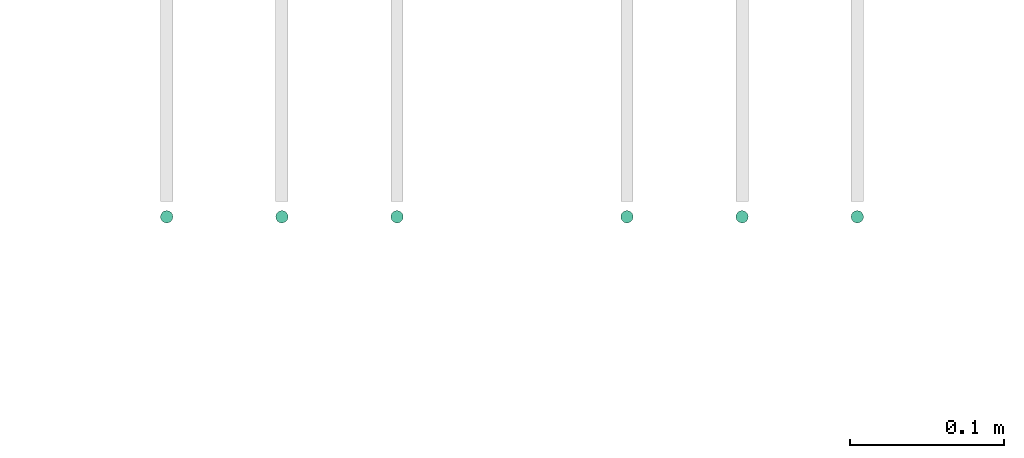
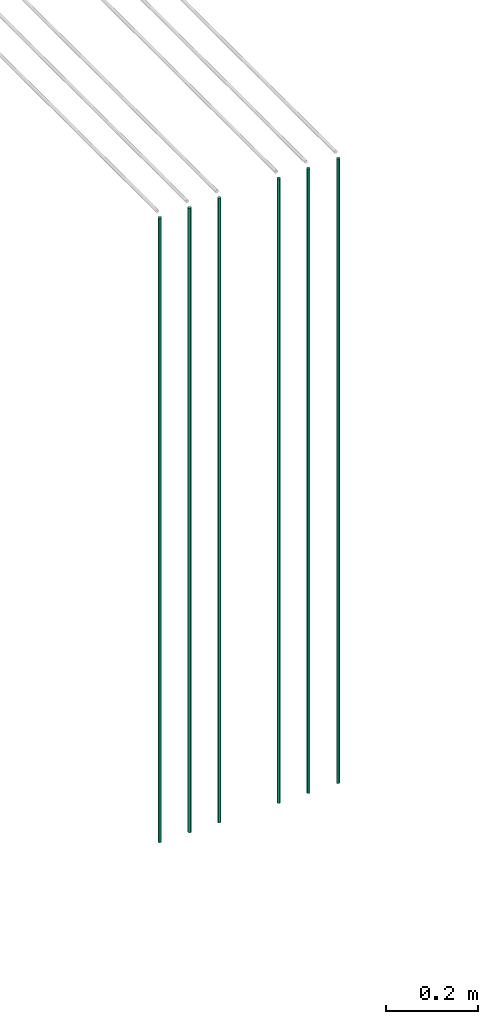
# One storey, part 6 of 89: 6 flow segments.
"""IFC2X3 building model written with IfcOpenShell, lengths in millimetres."""

import ifcopenshell
import ifcopenshell.guid

model = None  # the IFC model being written
_history = None  # IfcOwnerHistory: only IFC2X3 demands one
_inside = {}  # id of a spatial element -> (the spatial element, [elements in it])
_under = {}  # id of a project, library or spatial element -> (it, [spatial elements below it])
_declared = {}  # id of a project -> (the project, [libraries it declares])
_typed = {}  # id of a type object -> (the type object, [elements of that type])
_made_of = {}  # id of a material, layer set ... -> (it, [elements and type objects made of it])


def new_model(schema):
    """Start an empty IFC model of exactly this schema.

    Asked for "IFC4X3", IfcOpenShell would pick the latest addendum, in which some entities
    have other attributes; the version numbers below select the first issue.
    IFC2X3 requires an IfcOwnerHistory on every rooted entity: one is made here for all.
    """
    global model, _history
    if schema == "IFC4X3":
        model = ifcopenshell.file(schema_version=(4, 3, 0, 0))
    else:
        model = ifcopenshell.file(schema=schema)
    _inside.clear()
    _under.clear()
    _declared.clear()
    _typed.clear()
    _made_of.clear()
    _history = None
    if model.schema == "IFC2X3":
        org = make("IfcOrganization", Name="unknown")
        user = make(
            "IfcPersonAndOrganization",
            ThePerson=make("IfcPerson", FamilyName="unknown"),
            TheOrganization=org,
        )
        app = make(
            "IfcApplication",
            ApplicationDeveloper=org,
            Version="unknown",
            ApplicationFullName="unknown",
            ApplicationIdentifier="unknown",
        )
        _history = make(
            "IfcOwnerHistory",
            OwningUser=user,
            OwningApplication=app,
            ChangeAction="ADDED",
            CreationDate=0,
        )
    return model


def make(cls, **values):
    """One entity of the class cls with the attributes given. An attribute that is None is left unset."""
    return model.create_entity(
        cls, **{name: value for name, value in values.items() if value is not None}
    )


def entity(cls, *values):
    """Any entity or typed value of the class cls, its attributes in the order of the schema. None: left unset."""
    e = model.create_entity(cls)
    for i, value in enumerate(values):
        if value is not None:
            e[i] = value
    return e


def rooted(cls, **values):
    """An entity with a GlobalId (a new one), such as an element, a storey or a relation."""
    return make(cls, GlobalId=ifcopenshell.guid.new(), OwnerHistory=_history, **values)


def si_unit(unit_type, name, prefix=None):
    """IfcSIUnit, for example si_unit("LENGTHUNIT", "METRE", prefix="MILLI")."""
    return make("IfcSIUnit", UnitType=unit_type, Prefix=prefix, Name=name)


def converted_unit(unit_type, name, factor, base, dimensions=None, offset=None):
    """IfcConversionBasedUnit, such as the inch: factor (a typed value) times the base unit."""
    return make(
        "IfcConversionBasedUnit"
        if offset is None
        else "IfcConversionBasedUnitWithOffset",
        ConversionOffset=offset,
        Dimensions=None
        if dimensions is None
        else entity("IfcDimensionalExponents", *dimensions),
        UnitType=unit_type,
        Name=name,
        ConversionFactor=make(
            "IfcMeasureWithUnit", ValueComponent=factor, UnitComponent=base
        ),
    )


def derived_unit(unit_type, elements):
    """IfcDerivedUnit: a product of units, each with its exponent."""
    return make(
        "IfcDerivedUnit",
        Elements=[
            make("IfcDerivedUnitElement", Unit=unit, Exponent=power)
            for unit, power in elements
        ],
        UnitType=unit_type,
    )


def assignment(units):
    """IfcUnitAssignment: the units of a project."""
    return None if units is None else make("IfcUnitAssignment", Units=units)


def point(xyz):
    """IfcCartesianPoint."""
    return None if xyz is None else make("IfcCartesianPoint", Coordinates=xyz)


def direction(xyz):
    """IfcDirection."""
    return None if xyz is None else make("IfcDirection", DirectionRatios=xyz)


def frame(location, z_axis=None, x_axis=None):
    """IfcAxis2Placement3D, a coordinate frame: its origin and axes. An axis left out is left unset."""
    return make(
        "IfcAxis2Placement3D",
        Location=point(location),
        Axis=direction(z_axis),
        RefDirection=direction(x_axis),
    )


def frame_2d(location, x_axis=None):
    """IfcAxis2Placement2D, a coordinate frame in the plane: its origin and x axis."""
    return make(
        "IfcAxis2Placement2D", Location=point(location), RefDirection=direction(x_axis)
    )


def origin():
    """The frame at (0, 0, 0) with its axes left unset."""
    return frame((0.0, 0.0, 0.0))


def origin_2d_with_axis():
    """The frame at (0, 0) in the plane with the x axis (1, 0) written out."""
    return frame_2d((0.0, 0.0), x_axis=(1.0, 0.0))


def place(relative_to, where):
    """IfcLocalPlacement: puts the frame where relative to a parent placement (None: the world)."""
    return make(
        "IfcLocalPlacement", PlacementRelTo=relative_to, RelativePlacement=where
    )


def context(
    kind, dimensions, precision=None, world=None, true_north=None, identifier=None
):
    """IfcGeometricRepresentationContext, for example the 3D "Model" context."""
    return make(
        "IfcGeometricRepresentationContext",
        ContextIdentifier=identifier,
        ContextType=kind,
        CoordinateSpaceDimension=dimensions,
        Precision=precision,
        WorldCoordinateSystem=world,
        TrueNorth=true_north,
    )


def subcontext(parent, identifier, kind, view, scale=None):
    """IfcGeometricRepresentationSubContext, for example "Body" below "Model"."""
    return make(
        "IfcGeometricRepresentationSubContext",
        ContextIdentifier=identifier,
        ContextType=kind,
        ParentContext=parent,
        TargetScale=scale,
        TargetView=view,
    )


def project(units=None, contexts=None):
    """IfcProject with its units and contexts."""
    return rooted(
        "IfcProject",
        Name="project",
        RepresentationContexts=contexts,
        UnitsInContext=assignment(units),
    )


def spatial(cls, under=None, at=None, **own):
    """A site, building, storey or space (cls), placed at a placement, below another one or the project."""
    s = rooted(cls, ObjectPlacement=at, **own)
    if under is not None:
        _under.setdefault(under.id(), (under, []))[1].append(s)
    return s


def profile(cls, at=None, kind="AREA", **sizes):
    """A parametric profile (cls). Its sizes go by their IFC names, for example OverallWidth=200.0."""
    return make(cls, ProfileType=kind, Position=at, **sizes)


def circle(**sizes):
    """IfcCircleProfileDef."""
    return profile("IfcCircleProfileDef", **sizes)


def extrude(swept, where, along, depth):
    """IfcExtrudedAreaSolid: the profile swept, set in the frame where, extruded along a direction by depth."""
    return make(
        "IfcExtrudedAreaSolid",
        SweptArea=swept,
        Position=where,
        ExtrudedDirection=direction(along),
        Depth=depth,
    )


def shape(context_of_items, identifier, shape_type, items):
    """IfcShapeRepresentation: the items that make up one representation, for example the "Body"."""
    return make(
        "IfcShapeRepresentation",
        ContextOfItems=context_of_items,
        RepresentationIdentifier=identifier,
        RepresentationType=shape_type,
        Items=items,
    )


def made_of(thing, what):
    """Note that an element or type object is made of a material, layer set ...; save() writes the relation."""
    if what is not None:
        _made_of.setdefault(what.id(), (what, []))[1].append(thing)
    return thing


def type_object(cls, material=None, **own):
    """A type object (cls), such as IfcWallType, which elements share."""
    return made_of(rooted(cls, **own), material)


def element(
    cls,
    number,
    at=None,
    inside=None,
    cuts=None,
    type_object=None,
    material=None,
    context=None,
    identifier="Body",
    shape_type=None,
    held_by="IfcProductDefinitionShape",
    body=None,
    shapes=None,
    **own,
):
    """One element of the class cls, such as IfcWall. Its Tag is "e" and its number.

    at: its placement. inside: the storey or other place that contains it. cuts: it is an
    opening in that element (IfcRelVoidsElement). A single representation is given by context,
    identifier, shape_type and body (its items); several are given by shapes. held_by: the class
    of the entity that holds the representations. save() writes the other relations.
    """
    e = rooted(cls, Tag="e%d" % number, ObjectPlacement=at, **own)
    if body is not None:
        shapes = [shape(context, identifier, shape_type, body)]
    if shapes is not None:
        e.Representation = make(held_by, Representations=shapes)
    if inside is not None:
        _inside.setdefault(inside.id(), (inside, []))[1].append(e)
    if cuts is not None:
        rooted(
            "IfcRelVoidsElement", RelatingBuildingElement=cuts, RelatedOpeningElement=e
        )
    if type_object is not None:
        _typed.setdefault(type_object.id(), (type_object, []))[1].append(e)
    return made_of(e, material)


def aggregate(whole, parts):
    """IfcRelAggregates: a whole, such as a stair, and the parts it consists of."""
    return rooted("IfcRelAggregates", RelatingObject=whole, RelatedObjects=parts)


def save(model, path):
    """Write the relations noted so far, then the file.

    IfcRelAggregates (storeys below a building ...), IfcRelContainedInSpatialStructure (elements
    in a storey), IfcRelDefinesByType, IfcRelAssociatesMaterial and IfcRelDeclares: one each for
    every whole, place, type object, material and project.
    """
    for whole, parts in _under.values():
        aggregate(whole, parts)
    for where, things in _inside.values():
        rooted(
            "IfcRelContainedInSpatialStructure",
            RelatedElements=things,
            RelatingStructure=where,
        )
    for kind, things in _typed.values():
        rooted("IfcRelDefinesByType", RelatedObjects=things, RelatingType=kind)
    for what, things in _made_of.values():
        rooted("IfcRelAssociatesMaterial", RelatedObjects=things, RelatingMaterial=what)
    for by, libraries in _declared.values():
        rooted("IfcRelDeclares", RelatingContext=by, RelatedDefinitions=libraries)
    model.write(path)


model = new_model("IFC2X3")

# Units and contexts
model_context = context("Model", 3, precision=0.01, world=origin(), true_north=direction((6.12303176911189e-17, 1.0)))
body_context = subcontext(model_context, "Body", "Model", "MODEL_VIEW")
ifc_project = project(units=[si_unit("LENGTHUNIT", "METRE", prefix="MILLI"), si_unit("AREAUNIT", "SQUARE_METRE"), si_unit("VOLUMEUNIT", "CUBIC_METRE"), converted_unit("PLANEANGLEUNIT", "DEGREE", entity("IfcRatioMeasure", 0.0174532925199433), si_unit("PLANEANGLEUNIT", "RADIAN"), dimensions=[0, 0, 0, 0, 0, 0, 0]), si_unit("MASSUNIT", "GRAM", prefix="KILO"), derived_unit("MASSDENSITYUNIT", [(si_unit("MASSUNIT", "GRAM", prefix="KILO"), 1), (si_unit("LENGTHUNIT", "METRE"), -3)]), derived_unit("MOMENTOFINERTIAUNIT", [(si_unit("LENGTHUNIT", "METRE"), 4)]), si_unit("TIMEUNIT", "SECOND"), si_unit("FREQUENCYUNIT", "HERTZ"), si_unit("THERMODYNAMICTEMPERATUREUNIT", "DEGREE_CELSIUS"), derived_unit("THERMALTRANSMITTANCEUNIT", [(si_unit("MASSUNIT", "GRAM", prefix="KILO"), 1), (si_unit("THERMODYNAMICTEMPERATUREUNIT", "KELVIN"), -1), (si_unit("TIMEUNIT", "SECOND"), -3)]), derived_unit("VOLUMETRICFLOWRATEUNIT", [(si_unit("LENGTHUNIT", "METRE"), 3), (si_unit("TIMEUNIT", "SECOND"), -1)]), derived_unit("MASSFLOWRATEUNIT", [(si_unit("MASSUNIT", "GRAM", prefix="KILO"), 1), (si_unit("TIMEUNIT", "SECOND"), -1)]), derived_unit("ROTATIONALFREQUENCYUNIT", [(si_unit("TIMEUNIT", "SECOND"), -1)]), si_unit("ELECTRICCURRENTUNIT", "AMPERE"), si_unit("ELECTRICVOLTAGEUNIT", "VOLT"), si_unit("POWERUNIT", "WATT"), si_unit("FORCEUNIT", "NEWTON", prefix="KILO"), si_unit("ILLUMINANCEUNIT", "LUX"), si_unit("LUMINOUSFLUXUNIT", "LUMEN"), si_unit("LUMINOUSINTENSITYUNIT", "CANDELA"), derived_unit("USERDEFINED", [(si_unit("MASSUNIT", "GRAM", prefix="KILO"), -1), (si_unit("LENGTHUNIT", "METRE"), -2), (si_unit("TIMEUNIT", "SECOND"), 3), (si_unit("LUMINOUSFLUXUNIT", "LUMEN"), 1)]), derived_unit("LINEARVELOCITYUNIT", [(si_unit("LENGTHUNIT", "METRE"), 1), (si_unit("TIMEUNIT", "SECOND"), -1)]), si_unit("PRESSUREUNIT", "PASCAL"), derived_unit("USERDEFINED", [(si_unit("LENGTHUNIT", "METRE"), -2), (si_unit("MASSUNIT", "GRAM", prefix="KILO"), 1), (si_unit("TIMEUNIT", "SECOND"), -2)]), derived_unit("LINEARFORCEUNIT", [(si_unit("MASSUNIT", "GRAM", prefix="KILO"), 1), (si_unit("LENGTHUNIT", "METRE"), 1), (si_unit("TIMEUNIT", "SECOND"), -2), (si_unit("LENGTHUNIT", "METRE"), -1)]), derived_unit("PLANARFORCEUNIT", [(si_unit("MASSUNIT", "GRAM", prefix="KILO"), 1), (si_unit("LENGTHUNIT", "METRE"), 1), (si_unit("TIMEUNIT", "SECOND"), -2), (si_unit("LENGTHUNIT", "METRE"), -2)])], contexts=[model_context])

# Site, building, storey
site_placement = place(None, frame((0.0, -0.00077364408347762, 0.0)))
site = spatial("IfcSite", under=ifc_project, at=site_placement, CompositionType="ELEMENT")
building_placement = place(site_placement, origin())
building = spatial("IfcBuilding", under=site, at=building_placement, CompositionType="ELEMENT")
storey_placement = place(building_placement, frame((0.0, 0.0, 24000.0)))
storey = spatial("IfcBuildingStorey", under=building, at=storey_placement, CompositionType="ELEMENT", Elevation=24000.0)

# Flow segments
pipe_segment_type = type_object("IfcPipeSegmentType", PredefinedType="NOTDEFINED")
for number, where in (
    (1, (43030.0262171238, 14044.4047204552, 1400.0)),
    (2, (43105.0262171238, 14044.4047204552, 1400.0)),
    (3, (43180.0262171238, 14044.4047204552, 1400.0)),
    (4, (43329.7408194806, 14044.4047204552, 1400.0)),
    (5, (43404.7408194806, 14044.4047204552, 1400.0)),
    (6, (43479.7408194806, 14044.4047204552, 1400.0)),
):
    element("IfcFlowSegment", number, at=place(storey_placement, frame(where)), inside=storey, type_object=pipe_segment_type, context=body_context, shape_type="SweptSolid", body=[
        extrude(circle(Radius=4.0, at=origin_2d_with_axis()), frame((5.59527223591499, 5.59527223591499, 0.0)), (0.0, 0.0, 1.0), 1665.00000000002),
    ])

save(model, "model.ifc")
